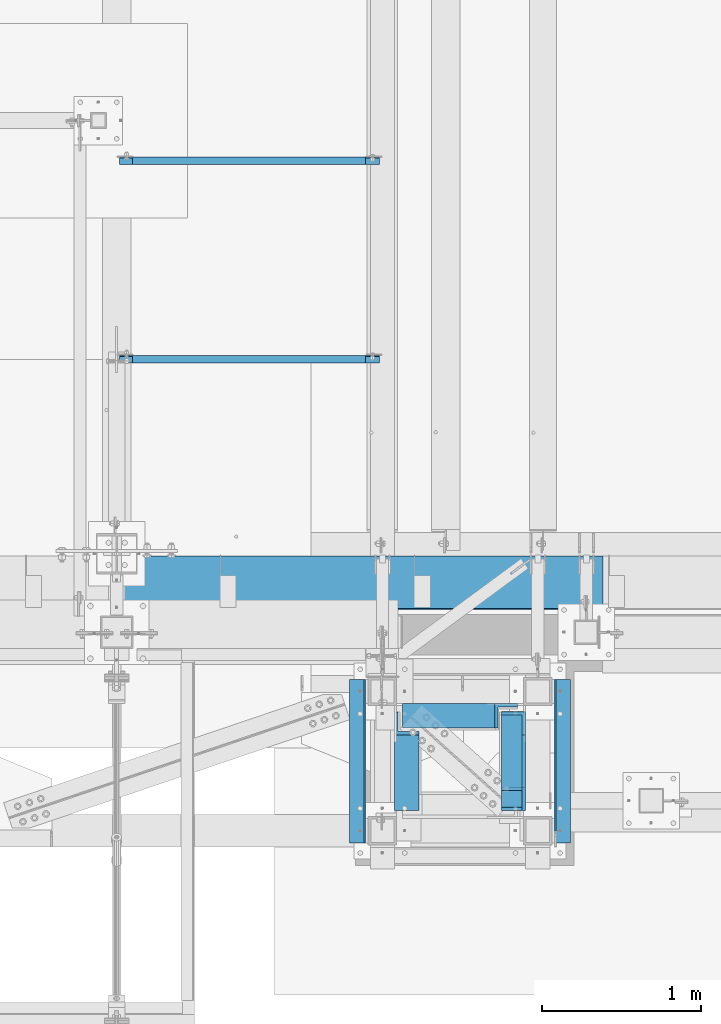
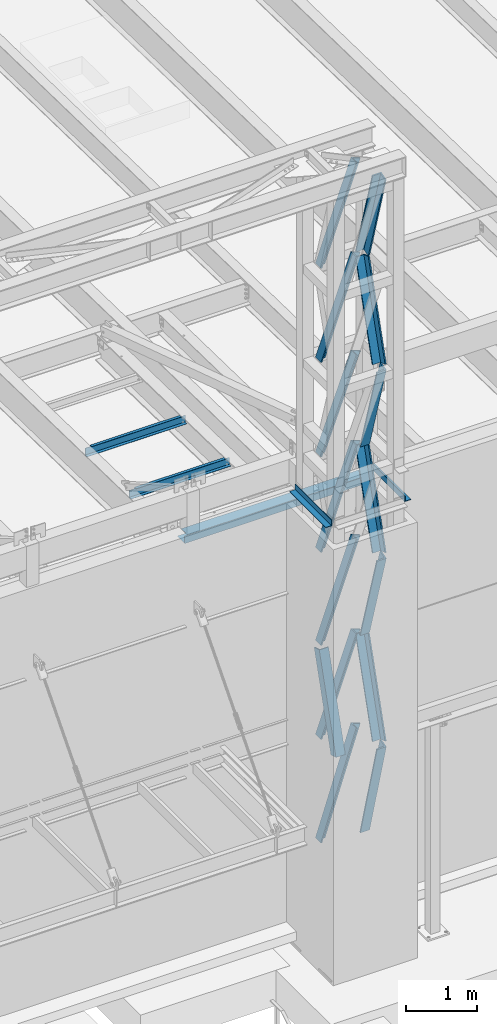
# One storey, part 1063 of 1763: 15 members, 5 beams, 4 elements without a shape of their own.
"""IFC2X3 building model written with IfcOpenShell, lengths in millimetres."""

from ifc_helpers import new_model, si_unit, frame, origin_with_axes, place, context, subcontext, project, spatial, faceted_brep, material, type_object, element, aggregate, save


model = new_model("IFC2X3")

# Units and contexts
model_context = context("Model", 3, precision=1e-05, world=origin_with_axes())
body_context = subcontext(model_context, "Body", "Model", "MODEL_VIEW")
ifc_project = project(units=[si_unit("LENGTHUNIT", "METRE", prefix="MILLI"), si_unit("AREAUNIT", "SQUARE_METRE"), si_unit("VOLUMEUNIT", "CUBIC_METRE"), si_unit("MASSUNIT", "GRAM", prefix="KILO"), si_unit("TIMEUNIT", "SECOND"), si_unit("PLANEANGLEUNIT", "RADIAN"), si_unit("SOLIDANGLEUNIT", "STERADIAN"), si_unit("THERMODYNAMICTEMPERATUREUNIT", "DEGREE_CELSIUS"), si_unit("LUMINOUSINTENSITYUNIT", "LUMEN")], contexts=[model_context])

# Site, building, storey
site_placement = place(None, origin_with_axes())
site = spatial("IfcSite", under=ifc_project, at=site_placement, CompositionType="ELEMENT")
building_placement = place(site_placement, origin_with_axes())
building = spatial("IfcBuilding", under=site, at=building_placement, Name="Undefined", CompositionType="ELEMENT")
storey_placement = place(building_placement, origin_with_axes())
storey = spatial("IfcBuildingStorey", under=building, at=storey_placement, Name="Undefined", CompositionType="ELEMENT", Elevation=0.0)

# Assembly, members
assembly_1_placement = place(storey_placement, origin_with_axes())
assembly_1 = element("IfcElementAssembly", 1, at=assembly_1_placement, inside=storey, Name="FRAME", AssemblyPlace="NOTDEFINED", PredefinedType="RIGID_FRAME")
ifc_material = material(Name="STEEL/A36")
member_type = type_object("IfcMemberType", Name="L6X6X7/8", PredefinedType="NOTDEFINED")
member_1_placement = place(assembly_1_placement, frame((-46913.2272043448, -14779.137653113, 16774.1203123683), z_axis=(-1.0, 0.0, 0.0), x_axis=(0.0, -0.28425468487658, 0.958748806583725)))
member_1 = element("IfcMember", 2, at=member_1_placement, type_object=member_type, material=ifc_material, Name="V. BRACE", ObjectType="L6X6X7/8", context=body_context, shape_type="Brep", body=[
    faceted_brep([(1.81898940354586e-12, -76.2000000000007, -53.9750000000604), (9.09494701772928e-13, -76.2000000000007, -76.2000000000844), (1668.42939139346, -76.2000000002827, -76.1999999999971), (1668.42939139346, -76.2000000002827, -53.9749999999985), (1.81898940354586e-12, 53.9750000000004, -53.9750000000604), (1668.42939139347, 53.9749999998239, -53.9749999999985), (0.0, 53.9750000000004, 76.2000000000771), (1668.42939139347, 53.9749999998239, 76.1999999999971), (0.0, 76.2000000000007, 76.2000000000771), (1668.42939139347, 76.1999999998425, 76.1999999999971), (9.09494701772928e-13, 76.2000000000007, -76.2000000000844), (1668.42939139347, 76.1999999998425, -76.1999999999971)], [[[0, 1, 2, 3]], [[4, 0, 3, 5]], [[6, 4, 5, 7]], [[8, 6, 7, 9]], [[1, 0, 4, 6, 8, 10]], [[1, 10, 11, 2]], [[7, 5, 3, 2, 11, 9]], [[10, 8, 9, 11]]]),
])
member_2_placement = place(assembly_1_placement, frame((-46913.2272043448, -14778.8696208458, 13524.110936), z_axis=(0.0, 0.957075661201097, 0.2898381940609), x_axis=(0.0, -0.2898381940609, 0.957075661201097)))
member_2 = element("IfcMember", 3, at=member_2_placement, type_object=member_type, material=ifc_material, Name="V. BRACE", ObjectType="L6X6X7/8", context=body_context, shape_type="Brep", body=[
    faceted_brep([(9.09494701772928e-13, 76.2000000000007, -76.2000000000844), (0.0, 76.2000000000007, 76.2000000000771), (1639.83084289621, 76.1999999999971, 76.1999999993677), (1639.83084289615, 76.1999999999971, -76.2000000006465), (0.0, 53.9750000000004, 76.2000000000771), (1639.83084289621, 53.9749999999985, 76.1999999993677), (1.81898940354586e-12, 53.9750000000004, -53.9750000000604), (1639.83084289616, 53.9749999999985, -53.9750000006443), (1.81898940354586e-12, -76.2000000000007, -53.9750000000604), (1639.83084289616, -76.1999999999971, -53.9750000006443), (9.09494701772928e-13, -76.2000000000007, -76.2000000000844), (1639.83084289615, -76.1999999999971, -76.2000000006465)], [[[0, 1, 2, 3]], [[1, 4, 5, 2]], [[4, 6, 7, 5]], [[6, 8, 9, 7]], [[8, 10, 11, 9]], [[10, 0, 3, 11]], [[5, 7, 9, 11, 3, 2]], [[10, 8, 6, 4, 1, 0]]]),
])
member_3_placement = place(assembly_1_placement, frame((-46913.2272043448, -15253.4500529566, 15149.115624), z_axis=(-1.0, 0.0, 0.0), x_axis=(0.0, 0.289497082081885, 0.957178896270741)))
member_3 = element("IfcMember", 4, at=member_3_placement, type_object=member_type, material=ifc_material, Name="V. BRACE", ObjectType="L6X6X7/8", context=body_context, shape_type="Brep", body=[
    faceted_brep([(9.09494701772928e-13, 76.2000000000007, -76.2000000000844), (0.0, 76.2000000000007, 76.2000000000771), (1639.65398114875, 76.1999999994368, 76.1999999999971), (1639.65398114875, 76.1999999994368, -76.1999999999971), (0.0, 53.9750000000004, 76.2000000000771), (1639.65398114874, 53.9749999994274, 76.1999999999971), (1.81898940354586e-12, 53.9750000000004, -53.9750000000604), (1639.65398114874, 53.9749999994274, -53.9749999999985), (1.81898940354586e-12, -76.2000000000007, -53.9750000000604), (1639.6539811487, -76.2000000006228, -53.9749999999985), (9.09494701772928e-13, -76.2000000000007, -76.2000000000844), (1639.6539811487, -76.2000000006228, -76.1999999999971)], [[[0, 1, 2, 3]], [[1, 4, 5, 2]], [[4, 6, 7, 5]], [[6, 8, 9, 7]], [[8, 10, 11, 9]], [[10, 0, 3, 11]], [[5, 7, 9, 11, 3, 2]], [[10, 8, 6, 4, 1, 0]]]),
])
member_4_placement = place(assembly_1_placement, frame((-46913.4806434013, -14778.8361401301, 10274.101560012), z_axis=(-0.00051033699985419, 0.95707420473217, 0.289842554143505), x_axis=(0.000154551999968596, -0.28984251293782, 0.957074340794679)))
member_4 = element("IfcMember", 5, at=member_4_placement, type_object=member_type, material=ifc_material, Name="V. BRACE", ObjectType="L6X6X7/8", context=body_context, shape_type="Brep", body=[
    faceted_brep([(9.09494701772928e-13, 76.2000000000007, -76.2000000000844), (0.0, 76.2000000000007, 76.2000000000771), (1639.83084289621, 76.1999999999971, 76.1999999993677), (1639.83084289615, 76.1999999999971, -76.2000000006465), (0.0, 53.9750000000004, 76.2000000000771), (1639.83084289621, 53.9749999999985, 76.1999999993677), (1.81898940354586e-12, 53.9750000000004, -53.9750000000604), (1639.83084289616, 53.9749999999985, -53.9750000006443), (1.81898940354586e-12, -76.2000000000007, -53.9750000000604), (1639.83084289616, -76.1999999999971, -53.9750000006443), (9.09494701772928e-13, -76.2000000000007, -76.2000000000844), (1639.83084289615, -76.1999999999971, -76.2000000006465)], [[[0, 1, 2, 3]], [[1, 4, 5, 2]], [[4, 6, 7, 5]], [[6, 8, 9, 7]], [[8, 10, 11, 9]], [[10, 0, 3, 11]], [[5, 7, 9, 11, 3, 2]], [[10, 8, 6, 4, 1, 0]]]),
])
member_5_placement = place(assembly_1_placement, frame((-46913.2272043448, -15253.4580728179, 11899.106248), z_axis=(-1.0, 0.0, 0.0), x_axis=(0.0, 0.289837226101388, 0.957075954334792)))
member_5 = element("IfcMember", 6, at=member_5_placement, type_object=member_type, material=ifc_material, Name="V. BRACE", ObjectType="L6X6X7/8", context=body_context, shape_type="Brep", body=[
    faceted_brep([(9.09494701772928e-13, 76.2000000000007, -76.2000000000844), (0.0, 76.2000000000007, 76.2000000000771), (1639.83084289621, 76.1999999999971, 76.1999999993677), (1639.83084289615, 76.1999999999971, -76.2000000006465), (0.0, 53.9750000000004, 76.2000000000771), (1639.83084289621, 53.9749999999985, 76.1999999993677), (1.81898940354586e-12, 53.9750000000004, -53.9750000000604), (1639.83084289616, 53.9749999999985, -53.9750000006443), (1.81898940354586e-12, -76.2000000000007, -53.9750000000604), (1639.83084289616, -76.1999999999971, -53.9750000006443), (9.09494701772928e-13, -76.2000000000007, -76.2000000000844), (1639.83084289615, -76.1999999999971, -76.2000000006465)], [[[0, 1, 2, 3]], [[1, 4, 5, 2]], [[4, 6, 7, 5]], [[6, 8, 9, 7]], [[8, 10, 11, 9]], [[10, 0, 3, 11]], [[5, 7, 9, 11, 3, 2]], [[10, 8, 6, 4, 1, 0]]]),
])
member_6_placement = place(assembly_1_placement, frame((-46913.2272043448, -14779.5096636888, 6870.7000000123), z_axis=(0.0, 0.964170339699174, 0.26528391591723), x_axis=(0.0, -0.26528391591723, 0.964170339699174)))
member_6 = element("IfcMember", 7, at=member_6_placement, type_object=member_type, material=ifc_material, Name="V. BRACE", ObjectType="L6X6X7/8", context=body_context, shape_type="Brep", body=[
    faceted_brep([(9.09494701772928e-13, 76.2000000000007, -76.2000000000844), (0.0, 76.2000000000007, 76.2000000000771), (1786.4452256684, 76.1999999999971, 76.2000000014923), (1786.44522566839, 76.1999999999971, -76.1999999985128), (0.0, 53.9750000000004, 76.2000000000771), (1786.4452256684, 53.9749999999985, 76.2000000014923), (1.81898940354586e-12, 53.9750000000004, -53.9750000000604), (1786.44522566839, 53.9749999999985, -53.9749999985124), (1.81898940354586e-12, -76.2000000000007, -53.9750000000604), (1786.44522566839, -76.1999999999971, -53.9749999985124), (9.09494701772928e-13, -76.2000000000007, -76.2000000000844), (1786.44522566839, -76.1999999999971, -76.1999999985128)], [[[0, 1, 2, 3]], [[1, 4, 5, 2]], [[4, 6, 7, 5]], [[6, 8, 9, 7]], [[8, 10, 11, 9]], [[10, 0, 3, 11]], [[5, 7, 9, 11, 3, 2]], [[10, 8, 6, 4, 1, 0]]]),
])
member_7_placement = place(assembly_1_placement, frame((-46913.2272043448, -15253.4567684263, 8648.7), z_axis=(-1.0, 0.0, 0.0), x_axis=(0.0, 0.288881147137844, 0.957364968456818)))
member_7 = element("IfcMember", 8, at=member_7_placement, type_object=member_type, material=ifc_material, Name="V. BRACE", ObjectType="L6X6X7/8", context=body_context, shape_type="Brep", body=[
    faceted_brep([(9.09494701772928e-13, 76.2000000000007, -76.2000000000844), (0.0, 76.2000000000007, 76.2000000000771), (1639.74984635749, 76.2000000008557, 76.1999999999971), (1639.74984635749, 76.2000000008557, -76.1999999999971), (0.0, 53.9750000000004, 76.2000000000771), (1639.7498463575, 53.9750000008426, 76.1999999999971), (1.81898940354586e-12, 53.9750000000004, -53.9750000000604), (1639.7498463575, 53.9750000008426, -53.9749999999985), (1.81898940354586e-12, -76.2000000000007, -53.9750000000604), (1639.74984635757, -76.1999999992149, -53.9749999999985), (9.09494701772928e-13, -76.2000000000007, -76.2000000000844), (1639.74984635757, -76.1999999992149, -76.1999999999971)], [[[0, 1, 2, 3]], [[1, 4, 5, 2]], [[4, 6, 7, 5]], [[6, 8, 9, 7]], [[8, 10, 11, 9]], [[10, 0, 3, 11]], [[5, 7, 9, 11, 3, 2]], [[10, 8, 6, 4, 1, 0]]]),
])
member_8_placement = place(assembly_1_placement, frame((-47583.1519986869, -15253.4567701277, 8648.7), z_axis=(1.0, 0.0, 0.0), x_axis=(0.0, 0.288881147137844, 0.957364968456818)))
member_8 = element("IfcMember", 9, at=member_8_placement, type_object=member_type, material=ifc_material, Name="V. BRACE", ObjectType="L6X6X7/8", context=body_context, shape_type="Brep", body=[
    faceted_brep([(9.09494701772928e-13, 76.2000000000007, -76.2000000000844), (0.0, 76.2000000000007, 76.2000000000771), (1639.74984635749, 76.2000000008557, 76.1999999999971), (1639.74984635749, 76.2000000008557, -76.1999999999971), (0.0, 53.9750000000004, 76.2000000000771), (1639.7498463575, 53.9750000008426, 76.1999999999971), (1.81898940354586e-12, 53.9750000000004, -53.9750000000604), (1639.7498463575, 53.9750000008426, -53.9749999999985), (1.81898940354586e-12, -76.2000000000007, -53.9750000000604), (1639.74984635757, -76.1999999992149, -53.9749999999985), (9.09494701772928e-13, -76.2000000000007, -76.2000000000844), (1639.74984635757, -76.1999999992149, -76.1999999999971)], [[[0, 1, 2, 3]], [[1, 4, 5, 2]], [[4, 6, 7, 5]], [[6, 8, 9, 7]], [[8, 10, 11, 9]], [[10, 0, 3, 11]], [[5, 7, 9, 11, 3, 2]], [[10, 8, 6, 4, 1, 0]]]),
])
member_9_placement = place(assembly_1_placement, frame((-47537.3451347226, -14732.0026277743, 16748.720536701), z_axis=(6.06694512680406e-06, -0.999999999981596, -1.54199369717389e-10), x_axis=(0.335283282133074, 2.03400000119903e-06, 0.942117360373927)))
member_9 = element("IfcMember", 10, at=member_9_placement, type_object=member_type, material=ifc_material, Name="V. BRACE", ObjectType="L6X6X7/8", context=body_context, shape_type="Brep", body=[
    faceted_brep([(9.09494701772928e-13, 76.2000000000007, -76.2000000000844), (0.0, 76.2000000000007, 76.2000000000771), (1724.84329343789, 76.1999999996478, 76.2000000010958), (1724.84329343754, 76.2000000000044, -76.1999999989348), (0.0, 53.9750000000004, 76.2000000000771), (1724.84329343786, 53.9749999996711, 76.2000000010812), (1.81898940354586e-12, 53.9750000000004, -53.9750000000604), (1724.84329343756, 53.9749999999767, -53.9749999989453), (1.81898940354586e-12, -76.2000000000007, -53.9750000000604), (1724.84329343738, -76.1999999998734, -53.9749999990436), (9.09494701772928e-13, -76.2000000000007, -76.2000000000844), (1724.84329343733, -76.1999999998225, -76.1999999990512)], [[[0, 1, 2, 3]], [[1, 4, 5, 2]], [[4, 6, 7, 5]], [[6, 8, 9, 7]], [[8, 10, 11, 9]], [[10, 0, 3, 11]], [[5, 7, 9, 11, 3, 2]], [[10, 8, 6, 4, 1, 0]]]),
])
member_10_placement = place(assembly_1_placement, frame((-47537.1146742549, -14732.002956019, 15123.715407458), z_axis=(0.0, -1.0, 0.0), x_axis=(0.334874224906127, 9.99999833869425e-10, 0.942262836735866)))
member_10 = element("IfcMember", 11, at=member_10_placement, type_object=member_type, material=ifc_material, Name="V. BRACE", ObjectType="L6X6X7/8", context=body_context, shape_type="Brep", body=[
    faceted_brep([(9.09494701772928e-13, 76.2000000000007, -76.2000000000844), (0.0, 76.2000000000007, 76.2000000000771), (1724.57686399414, 76.1999999983163, 76.1999999992258), (1724.57686399422, 76.1999999981927, -76.2000000007738), (0.0, 53.9750000000004, 76.2000000000771), (1724.57686399418, 53.974999998245, 76.1999999992295), (1.81898940354586e-12, 53.9750000000004, -53.9750000000604), (1724.57686399425, 53.9749999981432, -53.9750000007716), (1.81898940354586e-12, -76.2000000000007, -53.9750000000604), (1724.57686399449, -76.2000000022381, -53.9750000007571), (9.09494701772928e-13, -76.2000000000007, -76.2000000000844), (1724.5768639945, -76.2000000022599, -76.2000000007574)], [[[0, 1, 2, 3]], [[1, 4, 5, 2]], [[4, 6, 7, 5]], [[6, 8, 9, 7]], [[8, 10, 11, 9]], [[10, 0, 3, 11]], [[5, 7, 9, 11, 3, 2]], [[10, 8, 6, 4, 1, 0]]]),
])
member_11_placement = place(assembly_1_placement, frame((-47537.7849705428, -14732.002956019, 13498.710719458), z_axis=(0.0, -1.0, 0.0), x_axis=(0.349875295040666, 9.99999999198703e-10, 0.936796284108881)))
member_11 = element("IfcMember", 12, at=member_11_placement, type_object=member_type, material=ifc_material, Name="V. BRACE", ObjectType="L6X6X7/8", context=body_context, shape_type="Brep", body=[
    faceted_brep([(9.09494701772928e-13, 76.2000000000007, -76.2000000000844), (0.0, 76.2000000000007, 76.2000000000771), (1655.20577994027, 76.2000000011249, 76.1999999992604), (1655.20577994016, 76.2000000016196, -76.2000000007392), (0.0, 53.9750000000004, 76.2000000000771), (1655.20577994026, 53.9750000011918, 76.1999999992622), (1.81898940354586e-12, 53.9750000000004, -53.9750000000604), (1655.20577994017, 53.9750000016065, -53.9750000007371), (1.81898940354586e-12, -76.2000000000007, -53.9750000000604), (1655.20577994013, -76.199999998018, -53.975000000728), (9.09494701772928e-13, -76.2000000000007, -76.2000000000844), (1655.2057799401, -76.199999997938, -76.2000000007283)], [[[0, 1, 2, 3]], [[1, 4, 5, 2]], [[4, 6, 7, 5]], [[6, 8, 9, 7]], [[8, 10, 11, 9]], [[10, 0, 3, 11]], [[5, 7, 9, 11, 3, 2]], [[10, 8, 6, 4, 1, 0]]]),
])
member_12_placement = place(assembly_1_placement, frame((-47536.9219649802, -14732.002956019, 11849.099783458), z_axis=(0.0, -1.0, 0.0), x_axis=(0.330549340153199, 9.99999554506466e-10, 0.943788712437421)))
member_12 = element("IfcMember", 13, at=member_12_placement, type_object=member_type, material=ifc_material, Name="V. BRACE", ObjectType="L6X6X7/8", context=body_context, shape_type="Brep", body=[
    faceted_brep([(9.09494701772928e-13, 76.2000000000007, -76.2000000000844), (0.0, 76.2000000000007, 76.2000000000771), (1747.86042051722, 76.1999999938562, 76.199999999164), (1747.86042051722, 76.1999999937107, -76.2000000008356), (0.0, 53.9750000000004, 76.2000000000771), (1747.86042051722, 53.9749999938722, 76.1999999991804), (1.81898940354586e-12, 53.9750000000004, -53.9750000000604), (1747.86042051722, 53.9749999937558, -53.9750000008189), (1.81898940354586e-12, -76.2000000000007, -53.9750000000604), (1747.86042051721, -76.2000000061671, -53.9750000007189), (9.09494701772928e-13, -76.2000000000007, -76.2000000000844), (1747.86042051721, -76.2000000061889, -76.2000000007192)], [[[0, 1, 2, 3]], [[1, 4, 5, 2]], [[4, 6, 7, 5]], [[6, 8, 9, 7]], [[8, 10, 11, 9]], [[10, 0, 3, 11]], [[5, 7, 9, 11, 3, 2]], [[10, 8, 6, 4, 1, 0]]]),
])
member_13_placement = place(assembly_1_placement, frame((-47536.4531388462, -14732.002956019, 10248.70156), z_axis=(0.0, -1.0, 0.0), x_axis=(0.33466183911998, 9.99999794265608e-10, 0.942338290337834)))
member_13 = element("IfcMember", 14, at=member_13_placement, type_object=member_type, material=ifc_material, Name="V. BRACE", ObjectType="L6X6X7/8", context=body_context, shape_type="Brep", body=[
    faceted_brep([(9.09494701772928e-13, 76.2000000000007, -76.2000000000844), (0.0, 76.2000000000007, 76.2000000000771), (1724.4605169534, 76.1999999968903, 76.199999999204), (1724.46051695335, 76.1999999966574, -76.2000000007956), (0.0, 53.9750000000004, 76.2000000000771), (1724.46051695341, 53.9749999968262, 76.1999999992131), (1.81898940354586e-12, 53.9750000000004, -53.9750000000604), (1724.46051695337, 53.9749999966371, -53.975000000788), (1.81898940354586e-12, -76.2000000000007, -53.9750000000604), (1724.46051695341, -76.2000000037297, -53.9750000007334), (9.09494701772928e-13, -76.2000000000007, -76.2000000000844), (1724.4605169534, -76.2000000037588, -76.2000000007338)], [[[0, 1, 2, 3]], [[1, 4, 5, 2]], [[4, 6, 7, 5]], [[6, 8, 9, 7]], [[8, 10, 11, 9]], [[10, 0, 3, 11]], [[5, 7, 9, 11, 3, 2]], [[10, 8, 6, 4, 1, 0]]]),
])
member_14_placement = place(assembly_1_placement, frame((-47537.0341033946, -14732.002956019, 8623.29978345798), z_axis=(0.0, -1.0, 0.0), x_axis=(0.334512951060313, 1.00000043783993e-09, 0.942391153169914)))
member_14 = element("IfcMember", 15, at=member_14_placement, type_object=member_type, material=ifc_material, Name="V. BRACE", ObjectType="L6X6X7/8", context=body_context, shape_type="Brep", body=[
    faceted_brep([(9.09494701772928e-13, 76.2000000000007, -76.2000000000844), (0.0, 76.2000000000007, 76.2000000000771), (1724.76317823229, 76.1999999951586, 76.1999999991876), (1724.76317823233, 76.199999994933, -76.200000000812), (0.0, 53.9750000000004, 76.2000000000771), (1724.7631782323, 53.97499999516, 76.1999999992004), (1.81898940354586e-12, 53.9750000000004, -53.9750000000604), (1724.76317823234, 53.9749999949636, -53.9750000007989), (1.81898940354586e-12, -76.2000000000007, -53.9750000000604), (1724.76317823241, -76.2000000050757, -53.975000000717), (9.09494701772928e-13, -76.2000000000007, -76.2000000000844), (1724.76317823241, -76.2000000050975, -76.2000000007174)], [[[0, 1, 2, 3]], [[1, 4, 5, 2]], [[4, 6, 7, 5]], [[6, 8, 9, 7]], [[8, 10, 11, 9]], [[10, 0, 3, 11]], [[5, 7, 9, 11, 3, 2]], [[10, 8, 6, 4, 1, 0]]]),
])
member_15_placement = place(assembly_1_placement, frame((-47536.3195002302, -14732.002956019, 6845.3), z_axis=(0.0, -1.0, 0.0), x_axis=(0.308131522941648, 1.00000004810686e-09, 0.951343767819846)))
member_15 = element("IfcMember", 16, at=member_15_placement, type_object=member_type, material=ifc_material, Name="V. BRACE", ObjectType="L6X6X7/8", context=body_context, shape_type="Brep", body=[
    faceted_brep([(9.09494701772928e-13, 76.2000000000007, -76.2000000000844), (0.0, 76.2000000000007, 76.2000000000771), (1868.93512461962, 76.199999997596, 76.1999999991676), (1868.93512461956, 76.1999999976761, -76.2000000008338), (0.0, 53.9750000000004, 76.2000000000771), (1868.9351246196, 53.9749999976411, 76.1999999991676), (1.81898940354586e-12, 53.9750000000004, -53.9750000000604), (1868.93512461955, 53.9749999977066, -53.9750000008316), (1.81898940354586e-12, -76.2000000000007, -53.9750000000604), (1868.93512461943, -76.2000000020707, -53.975000000828), (9.09494701772928e-13, -76.2000000000007, -76.2000000000844), (1868.93512461942, -76.2000000020489, -76.2000000008265)], [[[0, 1, 2, 3]], [[1, 4, 5, 2]], [[4, 6, 7, 5]], [[6, 8, 9, 7]], [[8, 10, 11, 9]], [[10, 0, 3, 11]], [[5, 7, 9, 11, 3, 2]], [[10, 8, 6, 4, 1, 0]]]),
])

# Assembly, beam
assembly_2_placement = place(storey_placement, origin_with_axes())
assembly_2 = element("IfcElementAssembly", 17, at=assembly_2_placement, inside=storey, Name="CHANNEL", AssemblyPlace="NOTDEFINED", PredefinedType="RIGID_FRAME")
beam_type_1 = type_object("IfcBeamType", Name="C6X8.2", PredefinedType="NOTDEFINED")
beam_1_placement = place(assembly_2_placement, frame((-49402.4373044083, -11251.4001198498, 12076.4773623998), z_axis=(0.0, 0.0, 1.0), x_axis=(0.999999999999168, -1.29000000004882e-06, 0.0)))
beam_1 = element("IfcBeam", 18, at=beam_1_placement, type_object=beam_type_1, material=ifc_material, Name="CHANNEL", ObjectType="C6X8.2", context=body_context, shape_type="Brep", body=[
    faceted_brep([(87.3125001907392, 19.0499999999993, 50.8000000015782), (87.3125001907392, 23.8125, 50.8000000015782), (17.4624999999942, 23.8125, 50.8000000015782), (17.4624999999942, 19.0499999999993, 50.8000000015782), (92.1725797087856, 19.0499999999993, 51.7667299241657), (92.1725797087856, 23.8125, 51.7667299241657), (96.2927561769393, 19.0499999999993, 54.5197438246432), (96.2927561769393, 23.8125, 54.5197438246432), (99.0457700774132, 19.0499999999993, 58.6399202927969), (99.0457700774132, 23.8125, 58.6399202927969), (100.012500000004, 19.0499999999993, 63.4999998108433), (100.012500000004, 23.8125, 63.4999998108433), (100.012561428259, -23.81250000002, 76.2000000000007), (100.012500000004, 23.8125, 76.2000000000007), (100.012500000004, 19.0499999999993, 65.0887700000003), (100.012561428259, -23.81250000002, 72.2296624999999), (17.4624999999942, 19.0499999999993, -65.0887700000003), (17.4625614281395, -23.8125000000218, -72.2296624999999), (1648.61758921248, -23.8125000000218, -72.2296624999999), (1648.61752778026, 19.0499999999993, -65.0887700000003), (17.4625614281395, -23.8125000000218, -76.2000000000007), (1648.61758921248, -23.8125000000218, -76.2000000000007), (17.4624999999942, 23.8125, -76.2000000000007), (1648.61752778026, 23.8125, -76.2000000000007), (1648.61752778026, 23.8125, 50.7999999979074), (1648.61752778026, 19.0499999999993, 50.7999999979074), (1572.41752758952, 23.8125, 50.7999999979074), (1572.41752758952, 19.0499999999993, 50.7999999979074), (1567.55744807148, 23.8125, 51.766729920495), (1567.55744807148, 19.0499999999993, 51.766729920495), (1563.43727160332, 23.8125, 54.5197438209725), (1563.43727160332, 19.0499999999993, 54.5197438209725), (1560.68425770285, 23.8125, 58.6399202891262), (1560.68425770285, 19.0499999999993, 58.6399202891262), (1559.71752778026, 23.8125, 63.4999998071726), (1559.71752778026, 19.0499999999993, 63.4999998071726), (1559.71758921228, -23.8125000000218, 76.2000000000007), (1559.71758921228, -23.8125000000218, 72.2296624999999), (1559.71752778026, 19.0499999999993, 65.0887700000003), (1559.71752778026, 23.8125, 76.2000000000007)], [[[0, 1, 2, 3]], [[4, 5, 1, 0]], [[6, 7, 5, 4]], [[8, 9, 7, 6]], [[10, 11, 9, 8]], [[12, 13, 11, 10, 14, 15]], [[16, 17, 18, 19]], [[17, 20, 21, 18]], [[20, 22, 23, 21]], [[19, 18, 21, 23, 24, 25]], [[25, 24, 26, 27]], [[27, 26, 28, 29]], [[29, 28, 30, 31]], [[31, 30, 32, 33]], [[33, 32, 34, 35]], [[36, 37, 38, 35, 34, 39]], [[37, 36, 12, 15]], [[38, 37, 15, 14]], [[8, 6, 4, 0, 3, 16, 19, 25, 27, 29, 31, 33, 35, 38, 14, 10]], [[22, 20, 17, 16, 3, 2]], [[39, 34, 32, 30, 28, 26, 24, 23, 22, 2, 1, 5, 7, 9, 11, 13]], [[36, 39, 13, 12]]]),
])
aggregate(assembly_2, [beam_1])

assembly_3_placement = place(storey_placement, origin_with_axes())
assembly_3 = element("IfcElementAssembly", 19, at=assembly_3_placement, inside=storey, Name="CHANNEL", AssemblyPlace="NOTDEFINED", PredefinedType="RIGID_FRAME")
beam_2_placement = place(assembly_3_placement, frame((-49402.4372736983, -12495.6062192334, 12102.488636877), z_axis=(0.0, 0.0, 1.0), x_axis=(1.0, 0.0, 0.0)))
beam_2 = element("IfcBeam", 20, at=beam_2_placement, type_object=beam_type_1, material=ifc_material, Name="CHANNEL", ObjectType="C6X8.2", context=body_context, shape_type="Brep", body=[
    faceted_brep([(87.3125001907392, 19.0499999999993, 50.8000000015782), (87.3125001907392, 23.8125, 50.8000000015782), (17.4624999999942, 23.8125, 50.8000000015782), (17.4624999999942, 19.0499999999993, 50.8000000015782), (92.1725797087856, 19.0499999999993, 51.7667299241657), (92.1725797087856, 23.8125, 51.7667299241657), (96.2927561769393, 19.0499999999993, 54.5197438246432), (96.2927561769393, 23.8125, 54.5197438246432), (99.0457700774132, 19.0499999999993, 58.6399202927969), (99.0457700774132, 23.8125, 58.6399202927969), (100.012500000004, 19.0499999999993, 63.4999998108433), (100.012500000004, 23.8125, 63.4999998108433), (100.012500000004, -23.8125, 76.2000000000007), (100.012500000004, 23.8125, 76.2000000000007), (100.012500000004, 19.0499999999993, 65.0887700000003), (100.012500000004, -23.8125, 72.2296624999999), (17.4624999999942, 19.0499999999993, -65.0887700000003), (17.4624999999942, -23.8125, -72.2296624999999), (1648.61752778026, -23.8125, -72.2296624999999), (1648.61752778026, 19.0499999999993, -65.0887700000003), (17.4624999999942, -23.8125, -76.2000000000007), (1648.61752778026, -23.8125, -76.2000000000007), (17.4624999999942, 23.8125, -76.2000000000007), (1648.61752778026, 23.8125, -76.2000000000007), (1648.61752778026, 23.8125, 50.7999999979074), (1648.61752778026, 19.0499999999993, 50.7999999979074), (1572.41752758952, 23.8125, 50.7999999979074), (1572.41752758952, 19.0499999999993, 50.7999999979074), (1567.55744807148, 23.8125, 51.766729920495), (1567.55744807148, 19.0499999999993, 51.766729920495), (1563.43727160332, 23.8125, 54.5197438209725), (1563.43727160332, 19.0499999999993, 54.5197438209725), (1560.68425770285, 23.8125, 58.6399202891262), (1560.68425770285, 19.0499999999993, 58.6399202891262), (1559.71752778026, 23.8125, 63.4999998071726), (1559.71752778026, 19.0499999999993, 63.4999998071726), (1559.71752778026, -23.8125, 76.2000000000007), (1559.71752778026, -23.8125, 72.2296624999999), (1559.71752778026, 19.0499999999993, 65.0887700000003), (1559.71752778026, 23.8125, 76.2000000000007)], [[[0, 1, 2, 3]], [[4, 5, 1, 0]], [[6, 7, 5, 4]], [[8, 9, 7, 6]], [[10, 11, 9, 8]], [[12, 13, 11, 10, 14, 15]], [[16, 17, 18, 19]], [[17, 20, 21, 18]], [[20, 22, 23, 21]], [[19, 18, 21, 23, 24, 25]], [[25, 24, 26, 27]], [[27, 26, 28, 29]], [[29, 28, 30, 31]], [[31, 30, 32, 33]], [[33, 32, 34, 35]], [[36, 37, 38, 35, 34, 39]], [[37, 36, 12, 15]], [[38, 37, 15, 14]], [[8, 6, 4, 0, 3, 16, 19, 25, 27, 29, 31, 33, 35, 38, 14, 10]], [[22, 20, 17, 16, 3, 2]], [[39, 34, 32, 30, 28, 26, 24, 23, 22, 2, 1, 5, 7, 9, 11, 13]], [[36, 39, 13, 12]]]),
])
aggregate(assembly_3, [beam_2])

# Beam
beam_type_2 = type_object("IfcBeamType", Name="L4X4X3/8", PredefinedType="NOTDEFINED")
beam_3_placement = place(assembly_1_placement, frame((-46605.2522044142, -14503.4022155162, 12903.2000061035), z_axis=(1.0, 0.0, 0.0), x_axis=(0.0, -1.0, 0.0)))
beam_3 = element("IfcBeam", 21, at=beam_3_placement, type_object=beam_type_2, material=ifc_material, Name="ANGLE", ObjectType="L4X4X3/8", context=body_context, shape_type="Brep", body=[
    faceted_brep([(-3.63797880709171e-11, 50.8000000000011, -50.8000000000538), (-1.96450855582952e-10, 50.8000000000393, 50.7999999999374), (1025.5249938965, 50.7999999999993, 50.8000000000029), (1025.5249938965, 50.7999999999993, -50.8000000000029), (0.0, 41.2749999999996, 50.7999999999993), (1025.5249938965, 41.2749999999996, 50.8000000000029), (0.0, 41.2749999999996, -41.2750000000015), (1025.5249938965, 41.2749999999996, -41.2750000000015), (0.0, -50.7999999999993, -41.2750000000015), (1025.5249938965, -50.7999999999993, -41.2750000000015), (2.11002770811319e-10, -50.8000000000357, -50.799999999952), (1025.5249938965, -50.7999999999993, -50.8000000000029)], [[[0, 1, 2, 3]], [[1, 4, 5, 2]], [[4, 6, 7, 5]], [[6, 8, 9, 7]], [[8, 10, 11, 9]], [[10, 0, 3, 11]], [[5, 7, 9, 11, 3, 2]], [[10, 8, 6, 4, 1, 0]]]),
])

beam_4_placement = place(assembly_1_placement, frame((-47891.1273997268, -15528.9272094127, 12903.2), z_axis=(-1.0, 0.0, 0.0), x_axis=(0.0, 1.0, 0.0)))
beam_4 = element("IfcBeam", 22, at=beam_4_placement, type_object=beam_type_2, material=ifc_material, Name="ANGLE", ObjectType="L4X4X3/8", context=body_context, shape_type="Brep", body=[
    faceted_brep([(-3.63797880709171e-11, 50.8000000000011, -50.8000000000538), (-1.96450855582952e-10, 50.8000000000393, 50.7999999999374), (1025.5249938965, 50.7999999999993, 50.8000000000029), (1025.5249938965, 50.7999999999993, -50.8000000000029), (0.0, 41.2749999999996, 50.7999999999993), (1025.5249938965, 41.2749999999996, 50.8000000000029), (0.0, 41.2749999999996, -41.2750000000015), (1025.5249938965, 41.2749999999996, -41.2750000000015), (0.0, -50.7999999999993, -41.2750000000015), (1025.5249938965, -50.7999999999993, -41.2750000000015), (2.11002770811319e-10, -50.8000000000357, -50.799999999952), (1025.5249938965, -50.7999999999993, -50.8000000000029)], [[[0, 1, 2, 3]], [[1, 4, 5, 2]], [[4, 6, 7, 5]], [[6, 8, 9, 7]], [[8, 10, 11, 9]], [[10, 0, 3, 11]], [[5, 7, 9, 11, 3, 2]], [[10, 8, 6, 4, 1, 0]]]),
])

aggregate(assembly_1, [member_1, member_2, member_3, member_4, member_5, member_6, member_7, member_8, member_9, member_10, member_11, member_12, member_13, member_14, member_15, beam_3, beam_4])

# Assembly, beam
assembly_4_placement = place(storey_placement, origin_with_axes())
assembly_4 = element("IfcElementAssembly", 23, at=assembly_4_placement, inside=storey, Name="BEAM", AssemblyPlace="NOTDEFINED", PredefinedType="RIGID_FRAME")
beam_type_3 = type_object("IfcBeamType", PredefinedType="NOTDEFINED")
beam_5_placement = place(assembly_4_placement, frame((-47875.2622736984, -13728.6998186171, 12207.875), z_axis=(-1.0, 0.0, 0.0), x_axis=(0.0, -1.0, 0.0)))
beam_5 = element("IfcBeam", 24, at=beam_5_placement, type_object=beam_type_3, material=ifc_material, Name="BENT_PLATE", context=body_context, shape_type="Brep", body=[
    faceted_brep([(127.000180053716, -3.17499999999927, 1387.47500610352), (127.000180053716, 3.17499999999927, 1387.47500610352), (0.0, 3.17499999999927, 1387.47500610352), (0.0, -3.17499999999927, 1387.47500610352), (127.000180053716, -3.17499999999927, 1524.00000000002), (127.000180053716, 3.17499999999927, 1524.0), (336.550018310547, -3.17499999999927, -1524.0), (0.0, -3.17499999999927, -1523.99999999999), (0.0, 3.17499999999927, -1523.99999999999), (330.200016784669, 3.17499999999927, -1524.0), (330.19998779297, 123.824998474123, -1524.0), (336.549987792969, 123.825000000001, -1524.0), (330.200016784669, 3.17499999999927, 1524.0), (330.19998779297, 123.824998474123, 1524.0), (336.549987792969, 123.825000000001, 1524.0), (336.550018310547, -3.17499999999927, 1524.0)], [[[0, 1, 2, 3]], [[4, 5, 1, 0]], [[6, 7, 8, 9, 10, 11]], [[9, 12, 13, 10]], [[14, 11, 10, 13]], [[15, 6, 11, 14]], [[3, 7, 6, 15, 4, 0]], [[8, 7, 3, 2]], [[12, 9, 8, 2, 1, 5]], [[15, 14, 13, 12, 5, 4]]]),
])
aggregate(assembly_4, [beam_5])

save(model, "model.ifc")
